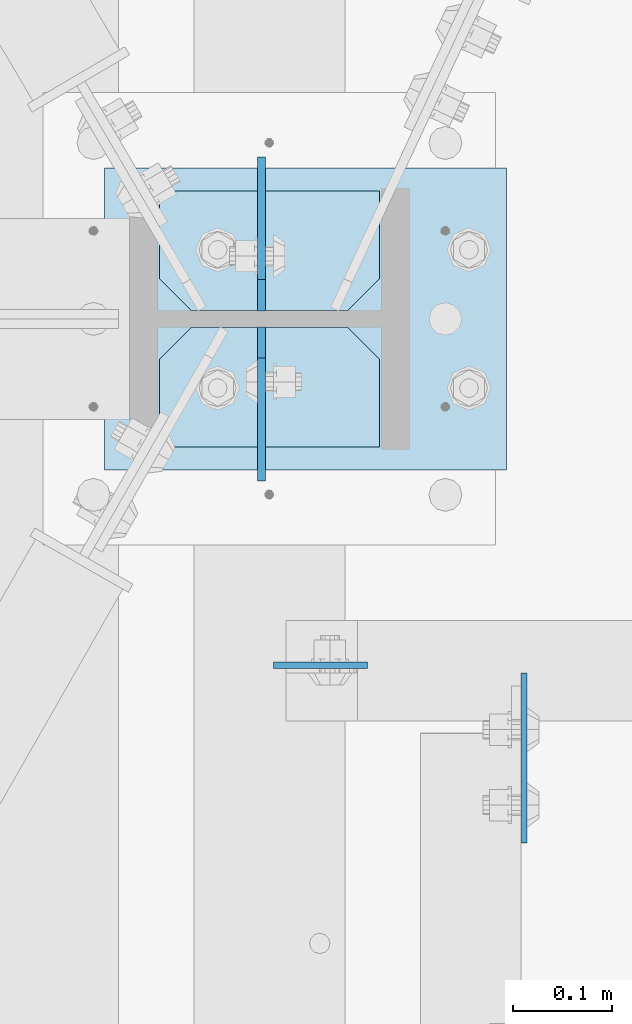
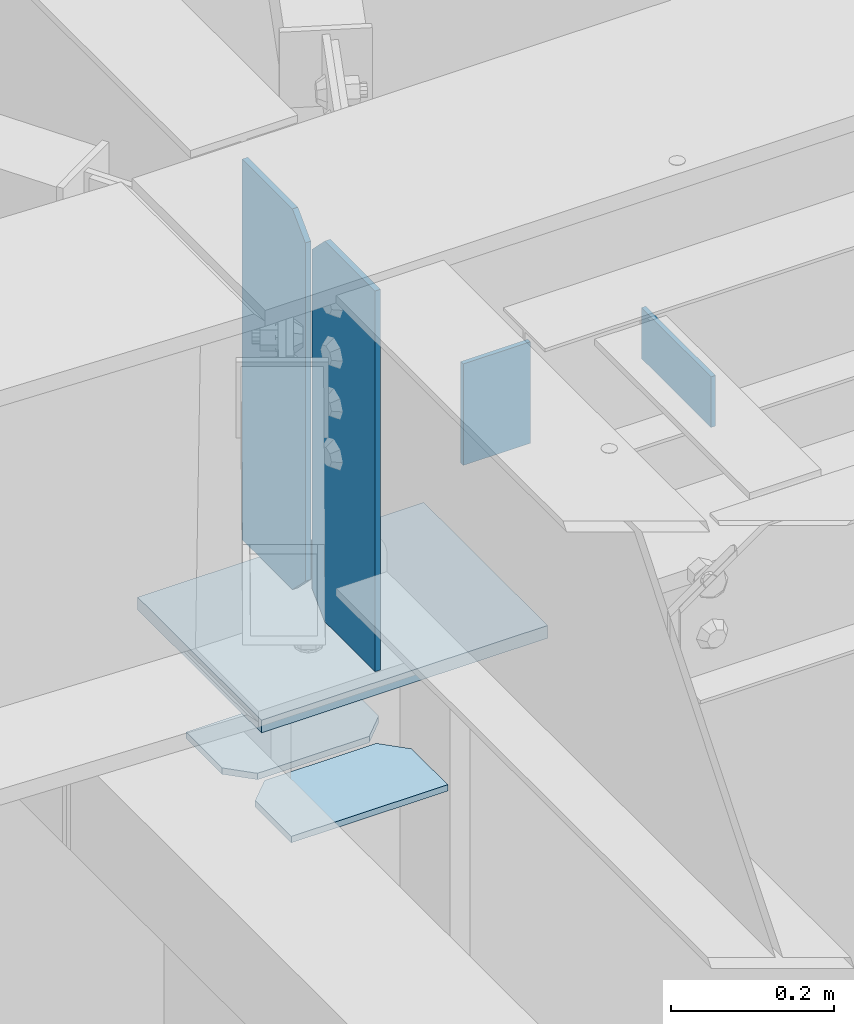
# One storey, part 1651 of 1763: 7 plates, 4 elements without a shape of their own.
"""IFC2X3 building model written with IfcOpenShell, lengths in millimetres."""

import ifcopenshell
import ifcopenshell.guid

model = None  # the IFC model being written
_history = None  # IfcOwnerHistory: only IFC2X3 demands one
_inside = {}  # id of a spatial element -> (the spatial element, [elements in it])
_under = {}  # id of a project, library or spatial element -> (it, [spatial elements below it])
_declared = {}  # id of a project -> (the project, [libraries it declares])
_typed = {}  # id of a type object -> (the type object, [elements of that type])
_made_of = {}  # id of a material, layer set ... -> (it, [elements and type objects made of it])


def new_model(schema):
    """Start an empty IFC model of exactly this schema.

    Asked for "IFC4X3", IfcOpenShell would pick the latest addendum, in which some entities
    have other attributes; the version numbers below select the first issue.
    IFC2X3 requires an IfcOwnerHistory on every rooted entity: one is made here for all.
    """
    global model, _history
    if schema == "IFC4X3":
        model = ifcopenshell.file(schema_version=(4, 3, 0, 0))
    else:
        model = ifcopenshell.file(schema=schema)
    _inside.clear()
    _under.clear()
    _declared.clear()
    _typed.clear()
    _made_of.clear()
    _history = None
    if model.schema == "IFC2X3":
        org = make("IfcOrganization", Name="unknown")
        user = make(
            "IfcPersonAndOrganization",
            ThePerson=make("IfcPerson", FamilyName="unknown"),
            TheOrganization=org,
        )
        app = make(
            "IfcApplication",
            ApplicationDeveloper=org,
            Version="unknown",
            ApplicationFullName="unknown",
            ApplicationIdentifier="unknown",
        )
        _history = make(
            "IfcOwnerHistory",
            OwningUser=user,
            OwningApplication=app,
            ChangeAction="ADDED",
            CreationDate=0,
        )
    return model


def make(cls, **values):
    """One entity of the class cls with the attributes given. An attribute that is None is left unset."""
    return model.create_entity(
        cls, **{name: value for name, value in values.items() if value is not None}
    )


def rooted(cls, **values):
    """An entity with a GlobalId (a new one), such as an element, a storey or a relation."""
    return make(cls, GlobalId=ifcopenshell.guid.new(), OwnerHistory=_history, **values)


def si_unit(unit_type, name, prefix=None):
    """IfcSIUnit, for example si_unit("LENGTHUNIT", "METRE", prefix="MILLI")."""
    return make("IfcSIUnit", UnitType=unit_type, Prefix=prefix, Name=name)


def assignment(units):
    """IfcUnitAssignment: the units of a project."""
    return None if units is None else make("IfcUnitAssignment", Units=units)


def point(xyz):
    """IfcCartesianPoint."""
    return None if xyz is None else make("IfcCartesianPoint", Coordinates=xyz)


def direction(xyz):
    """IfcDirection."""
    return None if xyz is None else make("IfcDirection", DirectionRatios=xyz)


def frame(location, z_axis=None, x_axis=None):
    """IfcAxis2Placement3D, a coordinate frame: its origin and axes. An axis left out is left unset."""
    return make(
        "IfcAxis2Placement3D",
        Location=point(location),
        Axis=direction(z_axis),
        RefDirection=direction(x_axis),
    )


def origin_with_axes():
    """The frame at (0, 0, 0) with the z axis (0, 0, 1) and the x axis (1, 0, 0) written out."""
    return frame((0.0, 0.0, 0.0), z_axis=(0.0, 0.0, 1.0), x_axis=(1.0, 0.0, 0.0))


def place(relative_to, where):
    """IfcLocalPlacement: puts the frame where relative to a parent placement (None: the world)."""
    return make(
        "IfcLocalPlacement", PlacementRelTo=relative_to, RelativePlacement=where
    )


def context(
    kind, dimensions, precision=None, world=None, true_north=None, identifier=None
):
    """IfcGeometricRepresentationContext, for example the 3D "Model" context."""
    return make(
        "IfcGeometricRepresentationContext",
        ContextIdentifier=identifier,
        ContextType=kind,
        CoordinateSpaceDimension=dimensions,
        Precision=precision,
        WorldCoordinateSystem=world,
        TrueNorth=true_north,
    )


def subcontext(parent, identifier, kind, view, scale=None):
    """IfcGeometricRepresentationSubContext, for example "Body" below "Model"."""
    return make(
        "IfcGeometricRepresentationSubContext",
        ContextIdentifier=identifier,
        ContextType=kind,
        ParentContext=parent,
        TargetScale=scale,
        TargetView=view,
    )


def project(units=None, contexts=None):
    """IfcProject with its units and contexts."""
    return rooted(
        "IfcProject",
        Name="project",
        RepresentationContexts=contexts,
        UnitsInContext=assignment(units),
    )


def spatial(cls, under=None, at=None, **own):
    """A site, building, storey or space (cls), placed at a placement, below another one or the project."""
    s = rooted(cls, ObjectPlacement=at, **own)
    if under is not None:
        _under.setdefault(under.id(), (under, []))[1].append(s)
    return s


def faces_of(points, faces, orient=None, outer=None):
    """IfcFace entities. A face is a list of loops; a loop is a list of indices into points, from 0.

    orient and outer hold one flag for each loop. By default every Orientation is true, the
    first loop of a face is its IfcFaceOuterBound and the others are IfcFaceBound.
    """
    made = []
    for i, loops in enumerate(faces):
        bounds = []
        for j, loop in enumerate(loops):
            is_outer = j == 0 if outer is None else outer[i][j]
            bounds.append(
                make(
                    "IfcFaceOuterBound" if is_outer else "IfcFaceBound",
                    Bound=make("IfcPolyLoop", Polygon=[points[k] for k in loop]),
                    Orientation=True if orient is None else orient[i][j],
                )
            )
        made.append(make("IfcFace", Bounds=bounds))
    return made


def faceted_brep(points, faces, orient=None, outer=None, voids=None):
    """IfcFacetedBrep: a solid bounded by flat faces; with voids (closed shells), ...WithVoids."""
    shared = [point(p) for p in points]
    hull = make("IfcClosedShell", CfsFaces=faces_of(shared, faces, orient, outer))
    if voids is None:
        return make("IfcFacetedBrep", Outer=hull)
    return make(
        "IfcFacetedBrepWithVoids",
        Outer=hull,
        Voids=[
            make(cls, CfsFaces=faces_of(shared, fs, o, b)) for cls, fs, o, b in voids
        ],
    )


def shape(context_of_items, identifier, shape_type, items):
    """IfcShapeRepresentation: the items that make up one representation, for example the "Body"."""
    return make(
        "IfcShapeRepresentation",
        ContextOfItems=context_of_items,
        RepresentationIdentifier=identifier,
        RepresentationType=shape_type,
        Items=items,
    )


def material(Name=None, Category=None):
    """IfcMaterial."""
    return make("IfcMaterial", Name=Name, Category=Category)


def made_of(thing, what):
    """Note that an element or type object is made of a material, layer set ...; save() writes the relation."""
    if what is not None:
        _made_of.setdefault(what.id(), (what, []))[1].append(thing)
    return thing


def type_object(cls, material=None, **own):
    """A type object (cls), such as IfcWallType, which elements share."""
    return made_of(rooted(cls, **own), material)


def element(
    cls,
    number,
    at=None,
    inside=None,
    cuts=None,
    type_object=None,
    material=None,
    context=None,
    identifier="Body",
    shape_type=None,
    held_by="IfcProductDefinitionShape",
    body=None,
    shapes=None,
    **own,
):
    """One element of the class cls, such as IfcWall. Its Tag is "e" and its number.

    at: its placement. inside: the storey or other place that contains it. cuts: it is an
    opening in that element (IfcRelVoidsElement). A single representation is given by context,
    identifier, shape_type and body (its items); several are given by shapes. held_by: the class
    of the entity that holds the representations. save() writes the other relations.
    """
    e = rooted(cls, Tag="e%d" % number, ObjectPlacement=at, **own)
    if body is not None:
        shapes = [shape(context, identifier, shape_type, body)]
    if shapes is not None:
        e.Representation = make(held_by, Representations=shapes)
    if inside is not None:
        _inside.setdefault(inside.id(), (inside, []))[1].append(e)
    if cuts is not None:
        rooted(
            "IfcRelVoidsElement", RelatingBuildingElement=cuts, RelatedOpeningElement=e
        )
    if type_object is not None:
        _typed.setdefault(type_object.id(), (type_object, []))[1].append(e)
    return made_of(e, material)


def aggregate(whole, parts):
    """IfcRelAggregates: a whole, such as a stair, and the parts it consists of."""
    return rooted("IfcRelAggregates", RelatingObject=whole, RelatedObjects=parts)


def save(model, path):
    """Write the relations noted so far, then the file.

    IfcRelAggregates (storeys below a building ...), IfcRelContainedInSpatialStructure (elements
    in a storey), IfcRelDefinesByType, IfcRelAssociatesMaterial and IfcRelDeclares: one each for
    every whole, place, type object, material and project.
    """
    for whole, parts in _under.values():
        aggregate(whole, parts)
    for where, things in _inside.values():
        rooted(
            "IfcRelContainedInSpatialStructure",
            RelatedElements=things,
            RelatingStructure=where,
        )
    for kind, things in _typed.values():
        rooted("IfcRelDefinesByType", RelatedObjects=things, RelatingType=kind)
    for what, things in _made_of.values():
        rooted("IfcRelAssociatesMaterial", RelatedObjects=things, RelatingMaterial=what)
    for by, libraries in _declared.values():
        rooted("IfcRelDeclares", RelatingContext=by, RelatedDefinitions=libraries)
    model.write(path)


model = new_model("IFC2X3")

# Units and contexts
model_context = context("Model", 3, precision=1e-05, world=origin_with_axes())
body_context = subcontext(model_context, "Body", "Model", "MODEL_VIEW")
ifc_project = project(units=[si_unit("LENGTHUNIT", "METRE", prefix="MILLI"), si_unit("AREAUNIT", "SQUARE_METRE"), si_unit("VOLUMEUNIT", "CUBIC_METRE"), si_unit("MASSUNIT", "GRAM", prefix="KILO"), si_unit("TIMEUNIT", "SECOND"), si_unit("PLANEANGLEUNIT", "RADIAN"), si_unit("SOLIDANGLEUNIT", "STERADIAN"), si_unit("THERMODYNAMICTEMPERATUREUNIT", "DEGREE_CELSIUS"), si_unit("LUMINOUSINTENSITYUNIT", "LUMEN")], contexts=[model_context])

# Site, building, storey
site_placement = place(None, origin_with_axes())
site = spatial("IfcSite", under=ifc_project, at=site_placement, CompositionType="ELEMENT")
building_placement = place(site_placement, origin_with_axes())
building = spatial("IfcBuilding", under=site, at=building_placement, Name="Undefined", CompositionType="ELEMENT")
storey_placement = place(building_placement, origin_with_axes())
storey = spatial("IfcBuildingStorey", under=building, at=storey_placement, Name="Undefined", CompositionType="ELEMENT", Elevation=0.0)

# Assembly, plate
assembly_1_placement = place(storey_placement, origin_with_axes())
assembly_1 = element("IfcElementAssembly", 1, at=assembly_1_placement, inside=storey, Name="BEAM", AssemblyPlace="NOTDEFINED", PredefinedType="RIGID_FRAME")
ifc_material = material(Name="STEEL/A36")
plate_type_1 = type_object("IfcPlateType", PredefinedType="NOTDEFINED")
plate_1_placement = place(assembly_1_placement, frame((-39415.1146174484, 57344.4687499993, 12420.6), z_axis=(0.0, -1.0, 0.0), x_axis=(0.0, 0.0, -1.0)))
plate_1 = element("IfcPlate", 2, at=plate_1_placement, type_object=plate_type_1, material=ifc_material, Name="PLATE", context=body_context, shape_type="Brep", body=[
    faceted_brep([(1.81898940354586e-12, -3.17500000000291, 0.0), (0.0, -3.17500000000291, 171.449996948242), (0.0, 3.17500000000291, 171.449996948242), (-1.81898940354586e-12, 3.17499999997381, 0.0), (76.1999969482422, -3.17500000000291, 171.449996948242), (76.1999969482422, 3.17500000000291, 171.449996948242), (76.1999969482422, -3.17500000000291, 0.0), (76.1999969482422, 3.17500000000291, 0.0)], [[[0, 1, 2, 3]], [[1, 4, 5, 2]], [[4, 6, 7, 5]], [[6, 0, 3, 7]], [[5, 7, 3, 2]], [[6, 4, 1, 0]]]),
])
aggregate(assembly_1, [plate_1])

# Assembly, plates
assembly_2_placement = place(storey_placement, origin_with_axes())
assembly_2 = element("IfcElementAssembly", 3, at=assembly_2_placement, inside=storey, Name="COLUMN", AssemblyPlace="NOTDEFINED", PredefinedType="RIGID_FRAME")
plate_type_2 = type_object("IfcPlateType", PredefinedType="NOTDEFINED")
plate_2_placement = place(assembly_2_placement, frame((-39561.1646174484, 57573.06875, 11610.975), z_axis=(-1.0, 0.0, 0.0), x_axis=(0.0, 1.0, 0.0)))
plate_2 = element("IfcPlate", 4, at=plate_2_placement, type_object=plate_type_2, material=ifc_material, Name="PLATE", context=body_context, shape_type="Brep", body=[
    faceted_brep([(0.0, -4.76249999999982, 0.0), (0.0, -4.76250000000073, 222.25), (0.0, 4.76250000000073, 222.25), (0.0, 4.76249999999982, 0.0), (88.9000015258789, -4.76250000000073, 222.25), (88.9000015258789, 4.76250000000073, 222.25), (120.650001525879, -4.76250000000073, 190.5), (120.650001525879, 4.76250000000073, 190.5), (120.650001525879, -4.76249999999709, 31.75), (120.650001525879, 4.76249999999709, 31.75), (88.9000015258789, -4.76249999999709, 0.0), (88.9000015258789, 4.76249999999709, 0.0)], [[[0, 1, 2, 3]], [[1, 4, 5, 2]], [[4, 6, 7, 5]], [[6, 8, 9, 7]], [[8, 10, 11, 9]], [[10, 0, 3, 11]], [[5, 7, 9, 11, 3, 2]], [[10, 8, 6, 4, 1, 0]]]),
])
plate_3_placement = place(assembly_2_placement, frame((-39561.1646174484, 57711.18125, 11610.975), z_axis=(-1.0, 0.0, 0.0), x_axis=(0.0, 1.0, 0.0)))
plate_3 = element("IfcPlate", 5, at=plate_3_placement, type_object=plate_type_2, material=ifc_material, Name="PLATE", context=body_context, shape_type="Brep", body=[
    faceted_brep([(0.0, -4.76250000000073, 31.75), (0.0, -4.76250000000073, 190.5), (0.0, 4.76250000000073, 190.5), (0.0, 4.76250000000073, 31.75), (31.75, -4.76250000000073, 222.25), (31.75, 4.76250000000073, 222.25), (120.650001525879, -4.76250000000073, 222.25), (120.650001525879, 4.76250000000073, 222.25), (120.650001525879, -4.76249999999709, 0.0), (120.650001525879, 4.76249999999709, 0.0), (31.75, -4.76250000000073, 0.0), (31.75, 4.76250000000073, 0.0)], [[[0, 1, 2, 3]], [[1, 4, 5, 2]], [[4, 6, 7, 5]], [[6, 8, 9, 7]], [[8, 10, 11, 9]], [[10, 0, 3, 11]], [[5, 7, 9, 11, 3, 2]], [[10, 8, 6, 4, 1, 0]]]),
])

# Assembly, plate
assembly_3_placement = place(storey_placement, origin_with_axes())
assembly_3 = element("IfcElementAssembly", 6, at=assembly_3_placement, inside=storey, Name="BEAM", AssemblyPlace="NOTDEFINED", PredefinedType="RIGID_FRAME")
plate_type_3 = type_object("IfcPlateType", PredefinedType="NOTDEFINED")
plate_4_placement = place(assembly_3_placement, frame((-39668.3208674408, 57352.4062499993, 12420.6), z_axis=(1.0, 0.0, 0.0), x_axis=(0.0, 0.0, -1.0)))
plate_4 = element("IfcPlate", 7, at=plate_4_placement, type_object=plate_type_3, material=ifc_material, Name="PLATE", context=body_context, shape_type="Brep", body=[
    faceted_brep([(1.81898940354586e-12, -3.17500000000291, 0.0), (0.0, -3.17499999999927, 95.25), (0.0, 3.17499999999927, 95.25), (-1.81898940354586e-12, 3.17499999997381, 0.0), (152.399993896484, -3.17500000000291, 95.25), (152.399993896484, 3.17500000000291, 95.25), (152.399993896484, -3.17500000000291, 0.0), (152.399993896484, 3.17500000000291, 0.0)], [[[0, 1, 2, 3]], [[1, 4, 5, 2]], [[4, 6, 7, 5]], [[6, 0, 3, 7]], [[5, 7, 3, 2]], [[6, 4, 1, 0]]]),
])
aggregate(assembly_3, [plate_4])

# Plate
plate_type_4 = type_object("IfcPlateType", PredefinedType="NOTDEFINED")
plate_5_placement = place(assembly_2_placement, frame((-39432.5771174484, 57854.85, 11814.175), z_axis=(-1.0, 0.0, 0.0), x_axis=(0.0, -1.0, 0.0)))
plate_5 = element("IfcPlate", 8, at=plate_5_placement, type_object=plate_type_4, material=ifc_material, Name="PLATE", context=body_context, shape_type="Brep", body=[
    faceted_brep([(0.0, -9.52500000000146, 0.0), (0.0, -9.52499999999964, 406.399993896484), (0.0, 9.52499999999964, 406.399993896484), (0.0, 9.52500000000146, 0.0), (304.799987792969, -9.52499999999964, 406.399993896484), (304.799987792969, 9.52499999999964, 406.399993896484), (304.799987792969, -9.52499999999998, 0.0), (304.799987792969, 9.52499999999998, 0.0)], [[[0, 1, 2, 3]], [[1, 4, 5, 2]], [[4, 6, 7, 5]], [[6, 0, 3, 7]], [[5, 7, 3, 2]], [[6, 4, 1, 0]]]),
])

aggregate(assembly_2, [plate_2, plate_3, plate_5])

# Assembly, plates
assembly_4_placement = place(storey_placement, origin_with_axes())
assembly_4 = element("IfcElementAssembly", 9, at=assembly_4_placement, inside=storey, Name="BEAM", AssemblyPlace="NOTDEFINED", PredefinedType="RIGID_FRAME")
plate_type_5 = type_object("IfcPlateType", PredefinedType="NOTDEFINED")
plate_6_placement = place(assembly_4_placement, frame((-39680.2266173835, 57710.3875, 12420.6), z_axis=(0.0, 1.0, 0.0), x_axis=(0.0, 0.0, -1.0)))
plate_6 = element("IfcPlate", 10, at=plate_6_placement, type_object=plate_type_5, material=ifc_material, Name="PLATE", context=body_context, shape_type="Brep", body=[
    faceted_brep([(0.0, -3.96899999999732, 31.75), (0.0, -3.96899999999732, 155.574996948242), (0.0, 3.96899999999732, 155.574996948242), (0.0, 3.96899999999732, 31.75), (571.5, -3.96899999999732, 155.574996948242), (571.5, 3.96899999999732, 155.574996948242), (571.5, -3.96899999999732, 31.75), (571.5, 3.96899999999732, 31.75), (539.75, -3.96899999999732, 0.0), (539.75, 3.96899999999732, 0.0), (31.75, -3.96899999999732, 0.0), (31.75, 3.96899999999732, 0.0)], [[[0, 1, 2, 3]], [[1, 4, 5, 2]], [[4, 6, 7, 5]], [[6, 8, 9, 7]], [[8, 10, 11, 9]], [[10, 0, 3, 11]], [[5, 7, 9, 11, 3, 2]], [[10, 8, 6, 4, 1, 0]]]),
])
plate_7_placement = place(assembly_4_placement, frame((-39680.226617376, 57694.5125, 12420.6), z_axis=(0.0, -1.0, 0.0), x_axis=(0.0, 0.0, -1.0)))
plate_7 = element("IfcPlate", 11, at=plate_7_placement, type_object=plate_type_5, material=ifc_material, Name="PLATE", context=body_context, shape_type="Brep", body=[
    faceted_brep([(0.0, -3.96899999999732, 31.75), (0.0, -3.96899999999732, 155.574996948242), (0.0, 3.96899999999732, 155.574996948242), (0.0, 3.96899999999732, 31.75), (571.5, -3.96899999999732, 155.574996948242), (571.5, 3.96899999999732, 155.574996948242), (571.5, -3.96899999999732, 31.75), (571.5, 3.96899999999732, 31.75), (539.75, -3.96899999999732, 0.0), (539.75, 3.96899999999732, 0.0), (31.75, -3.96899999999732, 0.0), (31.75, 3.96899999999732, 0.0)], [[[0, 1, 2, 3]], [[1, 4, 5, 2]], [[4, 6, 7, 5]], [[6, 8, 9, 7]], [[8, 10, 11, 9]], [[10, 0, 3, 11]], [[5, 7, 9, 11, 3, 2]], [[10, 8, 6, 4, 1, 0]]]),
])
aggregate(assembly_4, [plate_6, plate_7])

save(model, "model.ifc")
